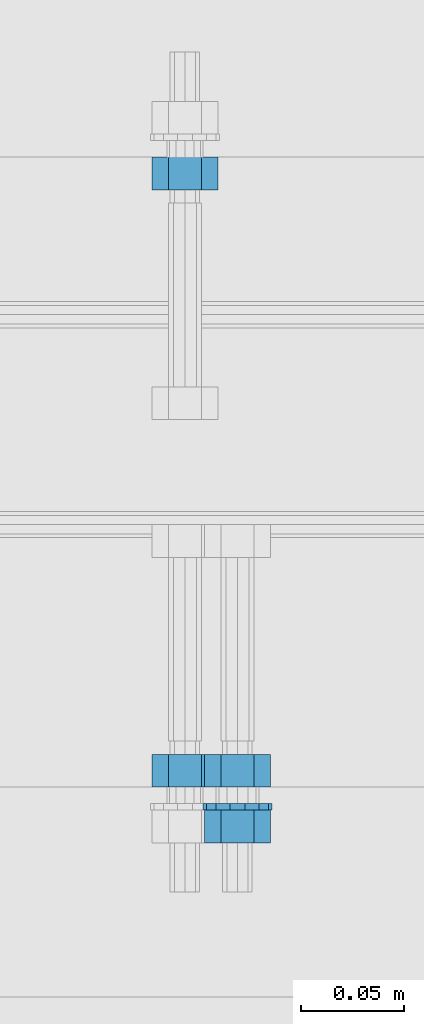
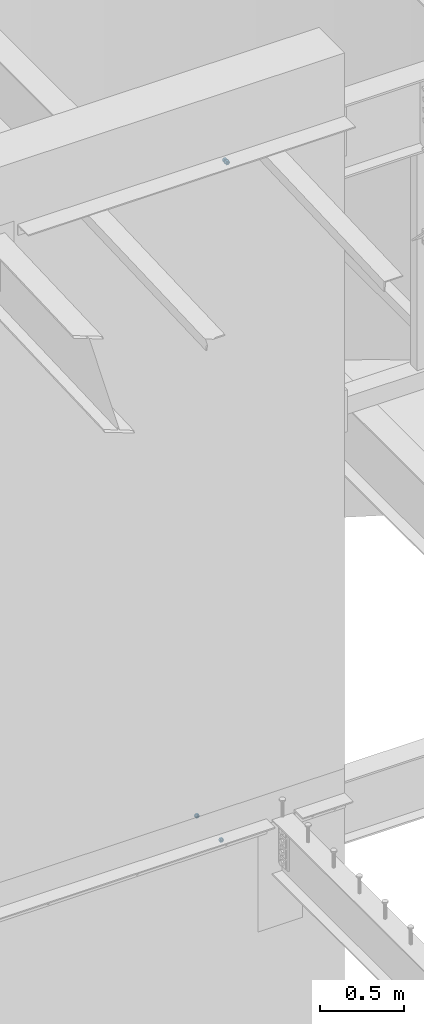
# One storey, part 623 of 975: 5 beams.
"""IFC2X3 building model written with IfcOpenShell, lengths in millimetres."""

from ifc_helpers import new_model, si_unit, frame, origin_with_axes, place, context, subcontext, project, spatial, faceted_brep, material, type_object, element, save


model = new_model("IFC2X3")

# Units and contexts
model_context = context("Model", 3, precision=1e-05, world=origin_with_axes())
body_context = subcontext(model_context, "Body", "Model", "MODEL_VIEW")
ifc_project = project(units=[si_unit("LENGTHUNIT", "METRE", prefix="MILLI"), si_unit("AREAUNIT", "SQUARE_METRE"), si_unit("VOLUMEUNIT", "CUBIC_METRE"), si_unit("MASSUNIT", "GRAM", prefix="KILO"), si_unit("TIMEUNIT", "SECOND"), si_unit("PLANEANGLEUNIT", "RADIAN"), si_unit("SOLIDANGLEUNIT", "STERADIAN"), si_unit("THERMODYNAMICTEMPERATUREUNIT", "DEGREE_CELSIUS"), si_unit("LUMINOUSINTENSITYUNIT", "LUMEN")], contexts=[model_context])

# Site, building, storey
site_placement = place(None, origin_with_axes())
site = spatial("IfcSite", under=ifc_project, at=site_placement, CompositionType="ELEMENT")
building_placement = place(site_placement, origin_with_axes())
building = spatial("IfcBuilding", under=site, at=building_placement, Name="Undefined", CompositionType="ELEMENT")
storey_placement = place(building_placement, origin_with_axes())
storey = spatial("IfcBuildingStorey", under=building, at=storey_placement, Name="Undefined", CompositionType="ELEMENT", Elevation=0.0)

# Beams
ifc_material_1 = material(Name="STEEL/F1554-36")
beam_type_1 = type_object("IfcBeamType", Name="5/8_HEAVY_HEX_NUT", PredefinedType="NOTDEFINED")
beam_1_placement = place(storey_placement, frame((13112.7500184963, 20443.8249972194, 8801.10000023449), z_axis=(0.0, 0.0, 1.0), x_axis=(0.0, 1.0, 0.0)))
element("IfcBeam", 1, at=beam_1_placement, inside=storey, type_object=beam_type_1, material=ifc_material_1, Name="HEADED_ANCHOR_BOLT", ObjectType="5/8_HEAVY_HEX_NUT", context=body_context, shape_type="Brep", body=[
    faceted_brep([(-1.09139364212751e-11, -15.8800001144436, -2.72848410531878e-12), (1.45519152283669e-11, -7.94000005722046, -13.7500000000036), (15.8750000000146, -7.94000005722137, -13.7500000000045), (15.8749999999891, -15.8800001144446, -2.72848410531878e-12), (2.91038304567337e-11, 7.94000005722319, -13.7500000000027), (15.8750000000291, 7.94000005722319, -13.7500000000027), (2.18278728425503e-11, 15.8800001144436, 9.09494701772928e-13), (15.8750000000218, 15.8800001144427, 9.09494701772928e-13), (-7.27595761418343e-12, 7.94000005722046, 13.7500000000027), (15.8749999999927, 7.94000005722046, 13.7500000000027), (-2.18278728425503e-11, -7.94000005722228, 13.7500000000009), (15.8749999999782, -7.94000005722319, 13.7500000000009), (-7.27595761418343e-12, 0.0, 8.72999954223724), (0.0, 3.78780484388062, 7.86545780435881), (15.875, 3.78780484387971, 7.86545780435881), (15.8749999999927, -9.09494701772928e-13, 8.72999954223724), (7.27595761418343e-12, 6.82538848405238, 5.44306568481716), (15.8750000000073, 6.82538848405238, 5.44306568481716), (1.09139364212751e-11, 8.51112022706275, 1.94260765157742), (15.8750000000109, 8.51112022706093, 1.94260765157651), (1.45519152283669e-11, 8.51112022706184, -1.94260765157651), (15.8750000000146, 8.51112022706184, -1.94260765157651), (2.18278728425503e-11, 6.8253884840542, -5.44306568481716), (15.8750000000218, 6.82538848405238, -5.44306568481716), (1.81898940354586e-11, 3.78780484388153, -7.86545780435881), (15.8750000000182, 3.78780484388062, -7.86545780435881), (1.81898940354586e-11, 9.09494701772928e-13, -8.72999954223997), (15.8750000000182, 9.09494701772928e-13, -8.72999954223997), (1.09139364212751e-11, -3.78780484387971, -7.86545780436063), (15.8750000000109, -3.78780484388062, -7.86545780436063), (3.63797880709171e-12, -6.82538848405238, -5.44306568481807), (15.8750000000036, -6.82538848405329, -5.44306568481807), (0.0, -8.51112022706184, -1.94260765157833), (15.875, -8.51112022706184, -1.94260765157833), (-7.27595761418343e-12, -8.51112022706184, 1.9426076515756), (15.8749999999927, -8.51112022706275, 1.9426076515756), (-1.09139364212751e-11, -6.82538848405329, 5.44306568481534), (15.8749999999927, -6.8253884840542, 5.44306568481534), (-7.27595761418343e-12, -3.78780484388062, 7.8654578043579), (15.8749999999927, -3.78780484388153, 7.8654578043579)], [[[0, 1, 2, 3]], [[1, 4, 5, 2]], [[4, 6, 7, 5]], [[6, 8, 9, 7]], [[8, 10, 11, 9]], [[10, 0, 3, 11]], [[12, 13, 14, 15]], [[13, 16, 17, 14]], [[16, 18, 19, 17]], [[18, 20, 21, 19]], [[20, 22, 23, 21]], [[22, 24, 25, 23]], [[24, 26, 27, 25]], [[26, 28, 29, 27]], [[28, 30, 31, 29]], [[30, 32, 33, 31]], [[32, 34, 35, 33]], [[34, 36, 37, 35]], [[36, 38, 39, 37]], [[38, 12, 15, 39]], [[5, 7, 9, 11, 3, 2], [17, 19, 21, 23, 25, 27, 29, 31, 33, 35, 37, 39, 15, 14]], [[10, 8, 6, 4, 1, 0], [38, 36, 34, 32, 30, 28, 26, 24, 22, 20, 18, 16, 13, 12]]]),
])
beam_2_placement = place(storey_placement, frame((13112.7500210199, 20416.8374972191, 8801.10000017628), z_axis=(0.0, 0.0, 1.0), x_axis=(0.0, 1.0, 0.0)))
element("IfcBeam", 2, at=beam_2_placement, inside=storey, type_object=beam_type_1, material=ifc_material_1, Name="HEADED_ANCHOR_BOLT", ObjectType="5/8_HEAVY_HEX_NUT", context=body_context, shape_type="Brep", body=[
    faceted_brep([(-1.09139364212751e-11, -15.8800001144436, -2.72848410531878e-12), (1.45519152283669e-11, -7.94000005722046, -13.7500000000036), (15.8750000000146, -7.94000005722137, -13.7500000000045), (15.8749999999891, -15.8800001144446, -2.72848410531878e-12), (2.91038304567337e-11, 7.94000005722319, -13.7500000000027), (15.8750000000291, 7.94000005722319, -13.7500000000027), (2.18278728425503e-11, 15.8800001144436, 9.09494701772928e-13), (15.8750000000218, 15.8800001144427, 9.09494701772928e-13), (-7.27595761418343e-12, 7.94000005722046, 13.7500000000027), (15.8749999999927, 7.94000005722046, 13.7500000000027), (-2.18278728425503e-11, -7.94000005722228, 13.7500000000009), (15.8749999999782, -7.94000005722319, 13.7500000000009), (-7.27595761418343e-12, 0.0, 8.72999954223724), (0.0, 3.78780484388062, 7.86545780435881), (15.875, 3.78780484387971, 7.86545780435881), (15.8749999999927, -9.09494701772928e-13, 8.72999954223724), (7.27595761418343e-12, 6.82538848405238, 5.44306568481716), (15.8750000000073, 6.82538848405238, 5.44306568481716), (1.09139364212751e-11, 8.51112022706275, 1.94260765157742), (15.8750000000109, 8.51112022706093, 1.94260765157651), (1.45519152283669e-11, 8.51112022706184, -1.94260765157651), (15.8750000000146, 8.51112022706184, -1.94260765157651), (2.18278728425503e-11, 6.8253884840542, -5.44306568481716), (15.8750000000218, 6.82538848405238, -5.44306568481716), (1.81898940354586e-11, 3.78780484388153, -7.86545780435881), (15.8750000000182, 3.78780484388062, -7.86545780435881), (1.81898940354586e-11, 9.09494701772928e-13, -8.72999954223997), (15.8750000000182, 9.09494701772928e-13, -8.72999954223997), (1.09139364212751e-11, -3.78780484387971, -7.86545780436063), (15.8750000000109, -3.78780484388062, -7.86545780436063), (3.63797880709171e-12, -6.82538848405238, -5.44306568481807), (15.8750000000036, -6.82538848405329, -5.44306568481807), (0.0, -8.51112022706184, -1.94260765157833), (15.875, -8.51112022706184, -1.94260765157833), (-7.27595761418343e-12, -8.51112022706184, 1.9426076515756), (15.8749999999927, -8.51112022706275, 1.9426076515756), (-1.09139364212751e-11, -6.82538848405329, 5.44306568481534), (15.8749999999927, -6.8253884840542, 5.44306568481534), (-7.27595761418343e-12, -3.78780484388062, 7.8654578043579), (15.8749999999927, -3.78780484388153, 7.8654578043579)], [[[0, 1, 2, 3]], [[1, 4, 5, 2]], [[4, 6, 7, 5]], [[6, 8, 9, 7]], [[8, 10, 11, 9]], [[10, 0, 3, 11]], [[12, 13, 14, 15]], [[13, 16, 17, 14]], [[16, 18, 19, 17]], [[18, 20, 21, 19]], [[20, 22, 23, 21]], [[22, 24, 25, 23]], [[24, 26, 27, 25]], [[26, 28, 29, 27]], [[28, 30, 31, 29]], [[30, 32, 33, 31]], [[32, 34, 35, 33]], [[34, 36, 37, 35]], [[36, 38, 39, 37]], [[38, 12, 15, 39]], [[5, 7, 9, 11, 3, 2], [17, 19, 21, 23, 25, 27, 29, 31, 33, 35, 37, 39, 15, 14]], [[10, 8, 6, 4, 1, 0], [38, 36, 34, 32, 30, 28, 26, 24, 22, 20, 18, 16, 13, 12]]]),
])
ifc_material_2 = material(Name="STEEL/A36")
beam_3_placement = place(storey_placement, frame((13087.3500244105, 20443.825, 3886.2), z_axis=(0.0, 0.0, 1.0), x_axis=(0.0, 1.0, 0.0)))
element("IfcBeam", 3, at=beam_3_placement, inside=storey, type_object=beam_type_1, material=ifc_material_2, Name="NUT", ObjectType="5/8_HEAVY_HEX_NUT", context=body_context, shape_type="Brep", body=[
    faceted_brep([(-1.09139364212751e-11, -15.8800001144436, -2.72848410531878e-12), (1.45519152283669e-11, -7.94000005722046, -13.7500000000036), (15.8750000000146, -7.94000005722137, -13.7500000000045), (15.8749999999891, -15.8800001144446, -2.72848410531878e-12), (2.91038304567337e-11, 7.94000005722319, -13.7500000000027), (15.8750000000291, 7.94000005722319, -13.7500000000027), (2.18278728425503e-11, 15.8800001144436, 9.09494701772928e-13), (15.8750000000218, 15.8800001144427, 9.09494701772928e-13), (-7.27595761418343e-12, 7.94000005722046, 13.7500000000027), (15.8749999999927, 7.94000005722046, 13.7500000000027), (-2.18278728425503e-11, -7.94000005722228, 13.7500000000009), (15.8749999999782, -7.94000005722319, 13.7500000000009), (-7.27595761418343e-12, 0.0, 8.72999954223724), (0.0, 3.78780484388062, 7.86545780435881), (15.875, 3.78780484387971, 7.86545780435881), (15.8749999999927, -9.09494701772928e-13, 8.72999954223724), (7.27595761418343e-12, 6.82538848405238, 5.44306568481716), (15.8750000000073, 6.82538848405238, 5.44306568481716), (1.09139364212751e-11, 8.51112022706275, 1.94260765157742), (15.8750000000109, 8.51112022706093, 1.94260765157651), (1.45519152283669e-11, 8.51112022706184, -1.94260765157651), (15.8750000000146, 8.51112022706184, -1.94260765157651), (2.18278728425503e-11, 6.8253884840542, -5.44306568481716), (15.8750000000218, 6.82538848405238, -5.44306568481716), (1.81898940354586e-11, 3.78780484388153, -7.86545780435881), (15.8750000000182, 3.78780484388062, -7.86545780435881), (1.81898940354586e-11, 9.09494701772928e-13, -8.72999954223997), (15.8750000000182, 9.09494701772928e-13, -8.72999954223997), (1.09139364212751e-11, -3.78780484387971, -7.86545780436063), (15.8750000000109, -3.78780484388062, -7.86545780436063), (3.63797880709171e-12, -6.82538848405238, -5.44306568481807), (15.8750000000036, -6.82538848405329, -5.44306568481807), (0.0, -8.51112022706184, -1.94260765157833), (15.875, -8.51112022706184, -1.94260765157833), (-7.27595761418343e-12, -8.51112022706184, 1.9426076515756), (15.8749999999927, -8.51112022706275, 1.9426076515756), (-1.09139364212751e-11, -6.82538848405329, 5.44306568481534), (15.8749999999927, -6.8253884840542, 5.44306568481534), (-7.27595761418343e-12, -3.78780484388062, 7.8654578043579), (15.8749999999927, -3.78780484388153, 7.8654578043579)], [[[0, 1, 2, 3]], [[1, 4, 5, 2]], [[4, 6, 7, 5]], [[6, 8, 9, 7]], [[8, 10, 11, 9]], [[10, 0, 3, 11]], [[12, 13, 14, 15]], [[13, 16, 17, 14]], [[16, 18, 19, 17]], [[18, 20, 21, 19]], [[20, 22, 23, 21]], [[22, 24, 25, 23]], [[24, 26, 27, 25]], [[26, 28, 29, 27]], [[28, 30, 31, 29]], [[30, 32, 33, 31]], [[32, 34, 35, 33]], [[34, 36, 37, 35]], [[36, 38, 39, 37]], [[38, 12, 15, 39]], [[5, 7, 9, 11, 3, 2], [17, 19, 21, 23, 25, 27, 29, 31, 33, 35, 37, 39, 15, 14]], [[10, 8, 6, 4, 1, 0], [38, 36, 34, 32, 30, 28, 26, 24, 22, 20, 18, 16, 13, 12]]]),
])
beam_4_placement = place(storey_placement, frame((13087.3500244105, 20748.6249996637, 3886.2), z_axis=(0.0, 0.0, -1.0), x_axis=(0.0, -1.0, 0.0)))
element("IfcBeam", 4, at=beam_4_placement, inside=storey, type_object=beam_type_1, material=ifc_material_2, Name="NUT", ObjectType="5/8_HEAVY_HEX_NUT", context=body_context, shape_type="Brep", body=[
    faceted_brep([(-1.09139364212751e-11, -15.8800001144436, -2.72848410531878e-12), (1.45519152283669e-11, -7.94000005722046, -13.7500000000036), (15.8750000000146, -7.94000005722137, -13.7500000000045), (15.8749999999891, -15.8800001144446, -2.72848410531878e-12), (2.91038304567337e-11, 7.94000005722319, -13.7500000000027), (15.8750000000291, 7.94000005722319, -13.7500000000027), (2.18278728425503e-11, 15.8800001144436, 9.09494701772928e-13), (15.8750000000218, 15.8800001144427, 9.09494701772928e-13), (-7.27595761418343e-12, 7.94000005722046, 13.7500000000027), (15.8749999999927, 7.94000005722046, 13.7500000000027), (-2.18278728425503e-11, -7.94000005722228, 13.7500000000009), (15.8749999999782, -7.94000005722319, 13.7500000000009), (-7.27595761418343e-12, 0.0, 8.72999954223724), (0.0, 3.78780484388062, 7.86545780435881), (15.875, 3.78780484387971, 7.86545780435881), (15.8749999999927, -9.09494701772928e-13, 8.72999954223724), (7.27595761418343e-12, 6.82538848405238, 5.44306568481716), (15.8750000000073, 6.82538848405238, 5.44306568481716), (1.09139364212751e-11, 8.51112022706275, 1.94260765157742), (15.8750000000109, 8.51112022706093, 1.94260765157651), (1.45519152283669e-11, 8.51112022706184, -1.94260765157651), (15.8750000000146, 8.51112022706184, -1.94260765157651), (2.18278728425503e-11, 6.8253884840542, -5.44306568481716), (15.8750000000218, 6.82538848405238, -5.44306568481716), (1.81898940354586e-11, 3.78780484388153, -7.86545780435881), (15.8750000000182, 3.78780484388062, -7.86545780435881), (1.81898940354586e-11, 9.09494701772928e-13, -8.72999954223997), (15.8750000000182, 9.09494701772928e-13, -8.72999954223997), (1.09139364212751e-11, -3.78780484387971, -7.86545780436063), (15.8750000000109, -3.78780484388062, -7.86545780436063), (3.63797880709171e-12, -6.82538848405238, -5.44306568481807), (15.8750000000036, -6.82538848405329, -5.44306568481807), (0.0, -8.51112022706184, -1.94260765157833), (15.875, -8.51112022706184, -1.94260765157833), (-7.27595761418343e-12, -8.51112022706184, 1.9426076515756), (15.8749999999927, -8.51112022706275, 1.9426076515756), (-1.09139364212751e-11, -6.82538848405329, 5.44306568481534), (15.8749999999927, -6.8253884840542, 5.44306568481534), (-7.27595761418343e-12, -3.78780484388062, 7.8654578043579), (15.8749999999927, -3.78780484388153, 7.8654578043579)], [[[0, 1, 2, 3]], [[1, 4, 5, 2]], [[4, 6, 7, 5]], [[6, 8, 9, 7]], [[8, 10, 11, 9]], [[10, 0, 3, 11]], [[12, 13, 14, 15]], [[13, 16, 17, 14]], [[16, 18, 19, 17]], [[18, 20, 21, 19]], [[20, 22, 23, 21]], [[22, 24, 25, 23]], [[24, 26, 27, 25]], [[26, 28, 29, 27]], [[28, 30, 31, 29]], [[30, 32, 33, 31]], [[32, 34, 35, 33]], [[34, 36, 37, 35]], [[36, 38, 39, 37]], [[38, 12, 15, 39]], [[5, 7, 9, 11, 3, 2], [17, 19, 21, 23, 25, 27, 29, 31, 33, 35, 37, 39, 15, 14]], [[10, 8, 6, 4, 1, 0], [38, 36, 34, 32, 30, 28, 26, 24, 22, 20, 18, 16, 13, 12]]]),
])
beam_type_2 = type_object("IfcBeamType", Name="5/8_WASHER", PredefinedType="NOTDEFINED")
beam_5_placement = place(storey_placement, frame((13112.7500194826, 20432.7124972189, 8801.10000026254), z_axis=(0.0, 0.0, 1.0), x_axis=(0.0, 1.0, 0.0)))
element("IfcBeam", 5, at=beam_5_placement, inside=storey, type_object=beam_type_2, material=ifc_material_1, Name="HEADED_ANCHOR_BOLT", ObjectType="5/8_WASHER", context=body_context, shape_type="Brep", body=[
    faceted_brep([(1.09139364212751e-11, -16.670000076293, -2.72848410531878e-12), (2.18278728425503e-11, -15.0191510966704, -7.23284196419536), (3.1750000000211, -15.0191510966711, -7.23284196419627), (3.17500000001019, -16.6700000762937, -1.81898940354586e-12), (2.91038304567337e-11, -10.3935750445523, -13.0331308723944), (3.17500000002838, -10.3935750445526, -13.0331308723953), (2.91038304567337e-11, -3.70942398602756, -16.2520483704566), (3.17500000002838, -3.70942398602779, -16.2520483704566), (2.5465851649642e-11, 3.70942398602961, -16.2520483704557), (3.17500000002474, 3.70942398602961, -16.2520483704566), (1.45519152283669e-11, 10.3935750445542, -13.0331308723935), (3.17500000001382, 10.3935750445537, -13.0331308723944), (0.0, 15.0191510966717, -7.23284196419354), (3.17499999999927, 15.0191510966713, -7.23284196419354), (-7.27595761418343e-12, 16.6700000762933, 0.0), (3.174999999992, 16.6700000762928, -9.09494701772928e-13), (-1.81898940354586e-11, 15.0191510966706, 7.23284196419354), (3.17499999998108, 15.0191510966704, 7.23284196419354), (-2.5465851649642e-11, 10.3935750445519, 13.0331308723926), (3.17499999997381, 10.3935750445517, 13.0331308723926), (-2.5465851649642e-11, 3.70942398602733, 16.2520483704538), (3.17499999997381, 3.7094239860271, 16.2520483704529), (-2.18278728425503e-11, -3.70942398602983, 16.2520483704529), (3.17499999997744, -3.70942398603006, 16.2520483704538), (-1.09139364212751e-11, -10.3935750445542, 13.0331308723908), (3.17499999998836, -10.3935750445544, 13.0331308723908), (0.0, -15.0191510966717, 7.23284196419172), (3.17499999999927, -15.019151096672, 7.23284196419081), (-7.27595761418343e-12, 0.0, 8.72999954223724), (0.0, 3.78780484388062, 7.86545780435881), (3.17499999998472, 3.78780484387903, 7.86545780435699), (3.17499999998836, -9.09494701772928e-13, 8.72999954223542), (7.27595761418343e-12, 6.82538848405238, 5.44306568481716), (3.17499999998836, 6.82538848405102, 5.44306568481534), (1.09139364212751e-11, 8.51112022706275, 1.94260765157742), (3.174999999992, 8.51112022705979, 1.94260765157651), (1.45519152283669e-11, 8.51112022706184, -1.94260765157651), (3.17499999999563, 8.51112022706025, -1.94260765157742), (2.18278728425503e-11, 6.8253884840542, -5.44306568481716), (3.17500000000655, 6.8253884840517, -5.44306568481807), (1.81898940354586e-11, 3.78780484388153, -7.86545780435881), (3.17500000001019, 3.78780484388017, -7.86545780435972), (1.81898940354586e-11, 9.09494701772928e-13, -8.72999954223997), (3.17500000001382, 6.82121026329696e-13, -8.72999954223997), (1.09139364212751e-11, -3.78780484387971, -7.86545780436063), (3.17500000001382, -3.78780484387994, -7.86545780436063), (3.63797880709171e-12, -6.82538848405238, -5.44306568481807), (3.17500000001019, -6.82538848405147, -5.44306568481898), (0.0, -8.51112022706184, -1.94260765157833), (3.17500000001019, -8.5111202270607, -1.94260765157924), (-7.27595761418343e-12, -8.51112022706184, 1.9426076515756), (3.17500000000291, -8.51112022706093, 1.94260765157469), (-1.09139364212751e-11, -6.82538848405329, 5.44306568481534), (3.17499999999563, -6.82538848405238, 5.44306568481534), (-7.27595761418343e-12, -3.78780484388062, 7.8654578043579), (3.174999999992, -3.78780484388085, 7.86545780435699)], [[[0, 1, 2, 3]], [[1, 4, 5, 2]], [[4, 6, 7, 5]], [[6, 8, 9, 7]], [[8, 10, 11, 9]], [[10, 12, 13, 11]], [[12, 14, 15, 13]], [[14, 16, 17, 15]], [[16, 18, 19, 17]], [[18, 20, 21, 19]], [[20, 22, 23, 21]], [[22, 24, 25, 23]], [[24, 26, 27, 25]], [[26, 0, 3, 27]], [[28, 29, 30, 31]], [[29, 32, 33, 30]], [[32, 34, 35, 33]], [[34, 36, 37, 35]], [[36, 38, 39, 37]], [[38, 40, 41, 39]], [[40, 42, 43, 41]], [[42, 44, 45, 43]], [[44, 46, 47, 45]], [[46, 48, 49, 47]], [[48, 50, 51, 49]], [[50, 52, 53, 51]], [[52, 54, 55, 53]], [[54, 28, 31, 55]], [[5, 7, 9, 11, 13, 15, 17, 19, 21, 23, 25, 27, 3, 2], [33, 35, 37, 39, 41, 43, 45, 47, 49, 51, 53, 55, 31, 30]], [[26, 24, 22, 20, 18, 16, 14, 12, 10, 8, 6, 4, 1, 0], [54, 52, 50, 48, 46, 44, 42, 40, 38, 36, 34, 32, 29, 28]]]),
])

save(model, "model.ifc")
